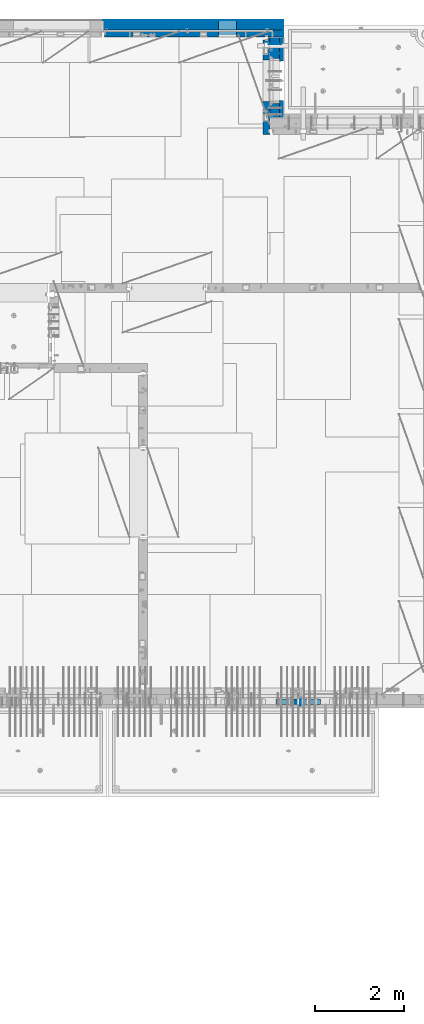
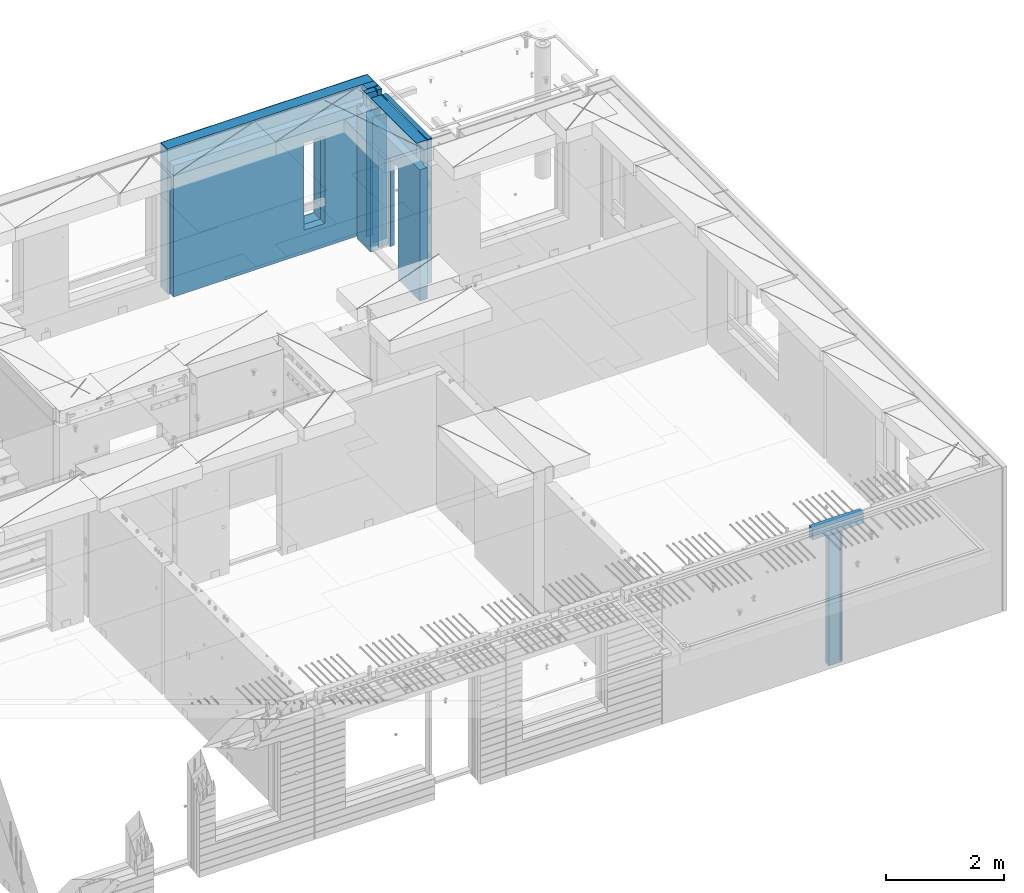
# One storey, part 240 of 349: 13 walls, 5 elements without a shape of their own.
"""IFC2X3 building model written with IfcOpenShell, lengths in millimetres."""

from ifc_helpers import new_model, si_unit, frame, origin_with_axes, place, context, subcontext, project, spatial, faceted_brep, material, type_object, element, aggregate, save


model = new_model("IFC2X3")

# Units and contexts
model_context = context("Model", 3, precision=1e-05, world=origin_with_axes())
body_context = subcontext(model_context, "Body", "Model", "MODEL_VIEW")
ifc_project = project(units=[si_unit("LENGTHUNIT", "METRE", prefix="MILLI"), si_unit("AREAUNIT", "SQUARE_METRE"), si_unit("VOLUMEUNIT", "CUBIC_METRE"), si_unit("MASSUNIT", "GRAM", prefix="KILO"), si_unit("TIMEUNIT", "SECOND"), si_unit("PLANEANGLEUNIT", "RADIAN"), si_unit("SOLIDANGLEUNIT", "STERADIAN"), si_unit("THERMODYNAMICTEMPERATUREUNIT", "DEGREE_CELSIUS"), si_unit("LUMINOUSINTENSITYUNIT", "LUMEN")], contexts=[model_context])

# Site, building, storey
site_placement = place(None, origin_with_axes())
site = spatial("IfcSite", under=ifc_project, at=site_placement, CompositionType="ELEMENT")
building_placement = place(site_placement, origin_with_axes())
building = spatial("IfcBuilding", under=site, at=building_placement, CompositionType="ELEMENT")
storey_placement = place(building_placement, origin_with_axes())
storey = spatial("IfcBuildingStorey", under=building, at=storey_placement, Name="4", CompositionType="ELEMENT", Elevation=0.0)

# Assembly, wall
assembly_1_placement = place(storey_placement, origin_with_axes())
assembly_1 = element("IfcElementAssembly", 1, at=assembly_1_placement, inside=storey, AssemblyPlace="NOTDEFINED", PredefinedType="REINFORCEMENT_UNIT")
ifc_material_1 = material(Name="Undefined")
wall_type_1 = type_object("IfcWallType", PredefinedType="NOTDEFINED")
wall_1_placement = place(assembly_1_placement, frame((32144.9998946285, 7780.0, 92115.0), z_axis=(0.0, 0.0, 1.0), x_axis=(0.0, -1.0, 0.0)))
wall_1 = element("IfcWall", 2, at=wall_1_placement, type_object=wall_type_1, material=ifc_material_1, Name="(PD)", context=body_context, shape_type="Brep", body=[
    faceted_brep([(0.0, 5.0, -1300.0), (0.0, 5.0, 1300.0), (180.0, 5.0, 1300.0), (180.0, 5.0, -1300.0), (0.0, -5.0, 1300.0), (180.0, -5.0, 1300.0), (0.0, -5.0, -1300.0), (180.0, -5.0, -1300.0)], [[[0, 1, 2, 3]], [[1, 4, 5, 2]], [[4, 6, 7, 5]], [[6, 0, 3, 7]], [[5, 7, 3, 2]], [[6, 4, 1, 0]]]),
])

# Assembly, walls
assembly_2_placement = place(storey_placement, origin_with_axes())
assembly_2 = element("IfcElementAssembly", 3, at=assembly_2_placement, inside=storey, AssemblyPlace="NOTDEFINED", PredefinedType="REINFORCEMENT_UNIT")
wall_2_placement = place(assembly_2_placement, frame((31429.9951872276, 22245.0, 92115.0), z_axis=(0.0, 0.0, 1.0), x_axis=(1.0, 0.0, 0.0)))
wall_2 = element("IfcWall", 4, at=wall_2_placement, type_object=wall_type_1, material=ifc_material_1, Name="(PD)", context=body_context, shape_type="Brep", body=[
    faceted_brep([(0.0, 5.0, -1300.0), (0.0, 5.0, 1300.0), (280.0, 5.0, 1300.0), (280.0, 5.0, -1300.0), (0.0, -5.0, 1300.0), (280.0, -5.0, 1300.0), (0.0, -5.0, -1300.0), (280.0, -5.0, -1300.0)], [[[0, 1, 2, 3]], [[1, 4, 5, 2]], [[4, 6, 7, 5]], [[6, 0, 3, 7]], [[5, 7, 3, 2]], [[6, 4, 1, 0]]]),
])
wall_3_placement = place(assembly_2_placement, frame((31429.9951872276, 22454.9997558594, 92115.0), z_axis=(0.0, 0.0, 1.0), x_axis=(1.0, 0.0, 0.0)))
wall_3 = element("IfcWall", 5, at=wall_3_placement, type_object=wall_type_1, material=ifc_material_1, Name="(PD)", context=body_context, shape_type="Brep", body=[
    faceted_brep([(0.0, 5.0, -1300.0), (0.0, 5.0, 1300.0), (280.0, 5.0, 1300.0), (280.0, 5.0, -1300.0), (0.0, -5.0, 1300.0), (280.0, -5.0, 1300.0), (0.0, -5.0, -1300.0), (280.0, -5.0, -1300.0)], [[[0, 1, 2, 3]], [[1, 4, 5, 2]], [[4, 6, 7, 5]], [[6, 0, 3, 7]], [[5, 7, 3, 2]], [[6, 4, 1, 0]]]),
])

# Assemblies, wall
assembly_3_placement = place(storey_placement, origin_with_axes())
assembly_3 = element("IfcElementAssembly", 6, at=assembly_3_placement, inside=storey, AssemblyPlace="NOTDEFINED", PredefinedType="REINFORCEMENT_UNIT")
assembly_4_placement = place(assembly_3_placement, origin_with_axes())
assembly_4 = element("IfcElementAssembly", 7, at=assembly_4_placement, Name="Steel Assembly", AssemblyPlace="NOTDEFINED", PredefinedType="NOTDEFINED")
aggregate(assembly_3, [assembly_4])
ifc_material_2 = material()
wall_type_2 = type_object("IfcWallType", PredefinedType="NOTDEFINED")
wall_4_placement = place(assembly_4_placement, frame((31599.9998568133, 7690.00021946163, 93590.0), z_axis=(0.0, 0.0, 1.0), x_axis=(1.0, 0.0, 0.0)))
wall_4 = element("IfcWall", 8, at=wall_4_placement, type_object=wall_type_2, material=ifc_material_2, context=body_context, shape_type="Brep", body=[
    faceted_brep([(0.0, 60.0, -120.0), (0.0, 60.0, 120.0), (1000.0, 60.0, 120.0), (1000.0, 60.0, -120.0), (0.0, -60.0, 120.0), (1000.0, -60.0, 120.0), (0.0, -60.0, -120.0), (1000.0, -60.0, -120.0)], [[[0, 1, 2, 3]], [[1, 4, 5, 2]], [[4, 6, 7, 5]], [[6, 0, 3, 7]], [[5, 7, 3, 2]], [[6, 4, 1, 0]]]),
])
aggregate(assembly_4, [wall_4])

# Wall
ifc_material_3 = material(Name="COS5gt")
wall_type_3 = type_object("IfcWallType", PredefinedType="NOTDEFINED")
wall_5_placement = place(assembly_2_placement, frame((31569.9951872276, 22605.0, 92247.5), z_axis=(0.0, 0.0, 1.0), x_axis=(0.0, -1.0, 0.0)))
wall_5 = element("IfcWall", 9, at=wall_5_placement, type_object=wall_type_3, material=ifc_material_3, context=body_context, shape_type="Brep", body=[
    faceted_brep([(0.0, 90.0, -1492.5), (0.0, 90.0, -1442.5), (465.000109818619, 90.0, -1442.5), (465.000109818619, 90.0, -1492.5), (0.0, -110.0, -1492.5), (465.000109818619, -110.0, -1492.5), (1800.0, -110.0, 1492.5), (1800.0, 90.0, 1492.5), (255.0, 90.0, 1492.5), (255.0, -110.0, 1492.5), (1800.0, 90.0, -1442.5), (1800.0, 90.0, -1492.5), (1475.00010981862, 90.0, -1492.5), (1475.00010981862, 90.0, -1442.5), (1800.0, 110.0, -1442.5), (1475.00010981862, 110.0, -1442.5), (1800.0, 110.0, 1442.5), (1800.0, 90.0, 1442.5), (1800.0, -110.0, -1492.5), (1475.00010981862, -110.0, -1492.5), (1475.00010981862, -110.000000000004, 857.5), (1475.00010981862, 110.0, 857.5), (465.000109818619, -110.000000000004, 857.5), (465.000109818619, 110.0, 857.5), (255.0, -110.0, 1222.5), (105.0, -110.0, 1222.5), (105.0, -110.0, 1492.5), (0.0, -110.0, 1492.5), (0.0, 90.0, 1492.5), (105.0, 90.0, 1492.5), (0.0, 110.0, 1442.5), (0.0, 90.0, 1442.5), (105.0, 90.0, 1442.5), (105.0, 110.0, 1442.5), (0.0, 110.0, -1442.5), (465.000109818619, 110.0, -1442.5), (105.0, 110.0, 1222.5), (255.0, 110.0, 1222.5), (255.0, 110.0, 1442.5), (255.0, 90.0, 1442.5)], [[[0, 1, 2, 3]], [[4, 0, 3, 5]], [[6, 7, 8, 9]], [[10, 11, 12, 13]], [[14, 10, 13, 15]], [[16, 17, 7, 6, 18, 11, 10, 14]], [[11, 18, 19, 12]], [[15, 13, 12, 19, 20, 21]], [[21, 20, 22, 23]], [[19, 18, 6, 9, 24, 25, 26, 27, 4, 5, 22, 20]], [[28, 27, 26, 29]], [[30, 31, 32, 33]], [[0, 4, 27, 28, 31, 30, 34, 1]], [[1, 34, 35, 2]], [[23, 22, 5, 3, 2, 35]], [[34, 30, 33, 36, 37, 38, 16, 14, 15, 21, 23, 35]], [[17, 16, 38, 39]], [[7, 17, 39, 8]], [[38, 37, 24, 9, 8, 39]], [[36, 25, 24, 37]], [[33, 32, 29, 26, 25, 36]], [[31, 28, 29, 32]]]),
])

# Assembly, walls
assembly_5_placement = place(storey_placement, origin_with_axes())
assembly_5 = element("IfcElementAssembly", 10, at=assembly_5_placement, inside=storey, AssemblyPlace="NOTDEFINED", PredefinedType="REINFORCEMENT_UNIT")
ifc_material_4 = material()
wall_6_placement = place(assembly_5_placement, frame((31645.0, 22620.0, 92247.5), z_axis=(0.0, 0.0, 1.0), x_axis=(0.0, 1.0, 0.0)))
wall_6 = element("IfcWall", 11, at=wall_6_placement, type_object=wall_type_3, material=ifc_material_4, context=body_context, shape_type="Brep", body=[
    faceted_brep([(0.0, 110.0, -1492.5), (0.0, 110.0, 1492.5), (150.0, 110.0, 1492.5), (150.0, 110.0, -1492.5), (0.0, -110.0, 1492.5), (150.0, -110.0, 1492.5), (0.0, -110.0, -1492.5), (150.0, -110.0, -1492.5)], [[[0, 1, 2, 3]], [[1, 4, 5, 2]], [[4, 6, 7, 5]], [[6, 0, 3, 7]], [[5, 7, 3, 2]], [[6, 4, 1, 0]]]),
])
wall_7_placement = place(assembly_5_placement, frame((27720.0, 22880.0, 92247.5), z_axis=(0.0, 0.0, 1.0), x_axis=(1.0, 0.0, 0.0)))
wall_7 = element("IfcWall", 12, at=wall_7_placement, type_object=wall_type_3, material=ifc_material_4, context=body_context, shape_type="Brep", body=[
    faceted_brep([(0.0, -110.0, -1492.5), (0.0, 110.0, -1492.5), (4035.0, 110.0, -1492.5), (4035.0, -110.0, -1492.5), (0.0, -110.0, 1492.5), (0.0, 110.0, 1492.5), (4035.0, -110.0, 1492.5), (4035.0, 110.0, 1492.5), (2584.99948280293, 110.0, -1002.5), (2994.99948280293, 110.0, -1002.5), (2994.99948280293, 110.0, 807.5), (2584.99948280293, 110.0, 807.5), (2584.99948280293, -110.0, -1002.5), (2584.99948280293, -110.0, 807.5), (2994.99948280293, -110.0, 807.5), (2994.99948280293, -110.0, -1002.5)], [[[0, 1, 2, 3]], [[0, 4, 5, 1]], [[5, 4, 6, 7]], [[1, 5, 7, 2], [8, 9, 10, 11]], [[6, 3, 2, 7]], [[4, 0, 3, 6], [12, 13, 14, 15]], [[10, 14, 13, 11]], [[9, 15, 14, 10]], [[8, 12, 15, 9]], [[11, 13, 12, 8]]]),
])

# Wall
ifc_material_5 = material(Name="CONCRETE/C30/37")
wall_type_4 = type_object("IfcWallType", PredefinedType="NOTDEFINED")
wall_8_placement = place(assembly_2_placement, frame((31722.4951872276, 22605.0, 92247.5), z_axis=(0.0, 0.0, 1.0), x_axis=(0.0, -1.0, 0.0)))
wall_8 = element("IfcWall", 13, at=wall_8_placement, type_object=wall_type_4, material=ifc_material_5, context=body_context, shape_type="Brep", body=[
    faceted_brep([(0.0, 32.4999992507037, 744.999999999258), (0.0, 32.4999991127006, 755.00000040044), (526.17471776616, 32.4999991126897, 755.000000400425), (526.174717749924, 32.4999992507001, 744.999999999229), (0.0, 42.5, 742.999999944761), (524.998050995091, 42.4999995462422, 742.999999944761), (0.0, 42.5, 606.999999889245), (524.998050995091, 42.4999994639038, 606.999999889245), (3.63797880709171e-12, 32.4999991127006, 605.00000040044), (526.17471776616, 32.4999991126897, 605.000000400425), (3.63797880709171e-12, 32.4999992507037, 594.999999999258), (526.174717749924, 32.4999992507001, 594.999999999229), (0.0, 42.5, 592.999999944761), (524.998050995091, 42.4999995343132, 592.999999944761), (0.0, 42.5, 456.999999889245), (524.998050995091, 42.4999994639038, 456.999999889245), (0.0, 32.4999991127006, 455.00000040044), (526.17471776616, 32.4999991126897, 455.000000400425), (0.0, 32.4999992507037, 444.999999999258), (526.174717749924, 32.4999992507001, 444.999999999229), (0.0, 42.5, 442.999999944761), (524.998050995091, 42.4999995254038, 442.999999944761), (0.0, 42.5, 306.999999889245), (524.998050995091, 42.4999994639038, 306.999999889245), (-3.63797880709171e-12, 32.4999991127006, 305.00000040044), (526.17471776616, 32.4999991126897, 305.000000400425), (-3.63797880709171e-12, 32.4999992507037, 294.999999999258), (526.174717749924, 32.4999992507001, 294.999999999229), (0.0, 42.5, 292.999999944761), (524.998050995091, 42.499999518499, 292.999999944761), (0.0, 42.5, 156.999999889245), (524.998050995091, 42.4999994639038, 156.999999889245), (-3.63797880709171e-12, 32.4999991127006, 155.00000040044), (526.17471776616, 32.4999991126897, 155.000000400425), (-3.63797880709171e-12, 32.4999992507037, 144.999999999258), (526.174717749924, 32.4999992507001, 144.999999999229), (0.0, 42.5, 142.999999944761), (524.998050995091, 42.4999995129838, 142.999999944761), (0.0, 42.5, 6.99999988924537), (524.998050995091, 42.4999994639038, 6.99999988924537), (0.0, 32.4999991127006, 5.0000004004396), (526.17471776616, 32.4999991126897, 5.00000040042505), (0.0, 32.4999992507037, -5.00000000074215), (526.174717749924, 32.4999992507001, -5.00000000077125), (0.0, 42.5, -7.00000005523907), (524.998050995091, 42.49999950848, -7.00000005523907), (0.0, 42.5, -143.000000110755), (524.998050995091, 42.4999994639038, -143.000000110755), (3.63797880709171e-12, 32.4999991127006, -144.99999959956), (526.17471776616, 32.4999991126897, -144.999999599575), (3.63797880709171e-12, 32.4999992507037, -155.000000000742), (526.174717749924, 32.4999992507001, -155.000000000771), (0.0, 42.5, -157.000000055239), (524.998050995091, 42.4999995047365, -157.000000055239), (0.0, 42.5, -293.000000110755), (524.998050995091, 42.4999994639038, -293.000000110755), (0.0, 32.4999991127006, -294.99999959956), (526.17471776616, 32.4999991126897, -294.999999599575), (0.0, 32.4999992507037, -305.000000000742), (526.174717749924, 32.4999992507001, -305.000000000771), (0.0, 42.5, -307.000000055239), (524.998050995091, 42.4999995015714, -307.000000055239), (0.0, 42.5, -443.000000110755), (524.998050995091, 42.4999994639038, -443.000000110755), (0.0, 32.4999991127006, -444.99999959956), (526.17471776616, 32.4999991126897, -444.999999599575), (0.0, 32.4999992507037, -455.000000000742), (526.174717749924, 32.4999992507001, -455.000000000771), (0.0, 42.5, -457.000000055239), (524.998050995091, 42.4999994988648, -457.000000055239), (0.0, 42.5, -593.000000110755), (524.998050995091, 42.4999994639038, -593.000000110755), (3.63797880709171e-12, 32.4999991127006, -594.99999959956), (526.17471776616, 32.4999991126897, -594.999999599575), (3.63797880709171e-12, 32.4999992507037, -605.000000000742), (526.174717749924, 32.4999992507001, -605.000000000771), (0.0, 42.5, -607.000000055239), (524.998050995091, 42.4999994965183, -607.000000055239), (0.0, 42.5, -743.000000110755), (524.998050995091, 42.4999994639038, -743.000000110755), (0.0, 32.4999991127006, -744.99999959956), (526.17471776616, 32.4999991126897, -744.999999599575), (0.0, 32.4999992507037, -755.000000000742), (526.174717749924, 32.4999992507001, -755.000000000771), (0.0, 42.5, -757.000000055239), (524.998050995091, 42.4999994944665, -757.000000055239), (0.0, 42.5, -893.000000110755), (524.998050995091, 42.4999994639038, -893.000000110755), (0.0, 32.4999991127006, -894.99999959956), (526.17471776616, 32.4999991126897, -894.999999599575), (0.0, 32.4999992507037, -905.000000000742), (526.174717749924, 32.4999992507001, -905.000000000771), (0.0, 42.5, -907.000000055239), (524.998050995091, 42.4999994926584, -907.000000055239), (0.0, 42.5, -1043.00000011075), (524.998050995091, 42.4999994639038, -1043.00000011075), (0.0, 32.4999991127006, -1044.99999959956), (526.17471776616, 32.4999991126897, -1044.99999959957), (0.0, 32.4999992507037, -1055.00000000074), (526.174717749924, 32.4999992507001, -1055.00000000077), (0.0, 42.5, -1057.00000005524), (524.998050995091, 42.499999491054, -1057.00000005524), (0.0, 42.5, -1193.00000011075), (524.998050995091, 42.4999994639038, -1193.00000011075), (0.0, 32.4999991127006, -1194.99999959956), (526.17471776616, 32.4999991126897, -1194.99999959957), (0.0, 32.4999992507037, -1205.00000000074), (526.174717749924, 32.4999992507001, -1205.00000000077), (0.0, 42.5, -1207.00000005524), (524.998050995091, 42.499999489617, -1207.00000005524), (0.0, 42.5, -1343.00000011075), (524.998050995091, 42.4999994639038, -1343.00000011075), (0.0, 32.4999991127006, -1344.99999959956), (526.17471776616, 32.4999991126897, -1344.99999959957), (0.0, 32.4999992507037, -1355.00000000074), (526.174717749924, 32.4999992507001, -1355.00000000077), (0.0, 42.5, -1357.00000005524), (524.998050995091, 42.5, -1357.00000005524), (0.0, 42.5, -1492.5), (524.998050995091, 42.5, -1492.5), (0.0, 42.5, 1356.99999988925), (0.0, 42.5, 1492.5), (105.0, 42.5, 1492.5), (105.0, 42.499999287309, 1356.99999988925), (0.0, -42.5, 1492.5), (105.0, -42.5, 1492.5), (1800.0, 32.4999991126897, 755.000000400425), (1800.0, 32.4999992507001, 744.999999999229), (1413.82138424026, 32.4999992507001, 744.999999999229), (1413.82138422402, 32.4999991126897, 755.000000400425), (1800.0, 42.5, 742.999999944761), (1414.99805099509, 42.4999998629828, 742.999999944761), (1800.0, 42.5, 606.999999889245), (1414.99805099509, 42.4999998381209, 606.999999889245), (1800.0, 32.4999991126897, 605.000000400425), (1413.82138422402, 32.4999991126897, 605.000000400425), (1800.0, 32.4999992507001, 594.999999999229), (1413.82138424026, 32.4999992507001, 594.999999999229), (1800.0, 42.5, 592.999999944761), (1414.99805099509, 42.4999998593812, 592.999999944761), (1800.0, 42.5, 456.999999889245), (1414.99805099509, 42.4999998381209, 456.999999889245), (1800.0, 32.4999991126897, 455.000000400425), (1413.82138422402, 32.4999991126897, 455.000000400425), (1800.0, 32.4999992507001, 444.999999999229), (1413.82138424026, 32.4999992507001, 444.999999999229), (1800.0, 42.5, 442.999999944761), (1414.99805099509, 42.4999998566891, 442.999999944761), (1800.0, 42.5, 306.999999889245), (1414.99805099509, 42.4999998381209, 306.999999889245), (1800.0, 32.4999991126897, 305.000000400425), (1413.82138422402, 32.4999991126897, 305.000000400425), (1800.0, 32.4999992507001, 294.999999999229), (1413.82138424026, 32.4999992507001, 294.999999999229), (1800.0, 42.5, 292.999999944761), (1414.99805099509, 42.4999998546045, 292.999999944761), (1800.0, 42.5, 156.999999889245), (1414.99805099509, 42.4999998381209, 156.999999889245), (1800.0, 32.4999991126897, 155.000000400425), (1413.82138422402, 32.4999991126897, 155.000000400425), (1800.0, 32.4999992507001, 144.999999999229), (1413.82138424026, 32.4999992507001, 144.999999999229), (1800.0, 42.5, 142.999999944761), (1414.99805099509, 42.4999998529383, 142.999999944761), (1800.0, 42.5, 6.99999988924537), (1414.99805099509, 42.4999998381209, 6.99999988924537), (1800.0, 32.4999991126897, 5.00000040042505), (1413.82138422402, 32.4999991126897, 5.00000040042505), (1800.0, 32.4999992507001, -5.00000000077125), (1413.82138424026, 32.4999992507001, -5.00000000077125), (1800.0, 42.5, -7.00000005523907), (1414.99805099509, 42.4999998515814, -7.00000005523907), (1800.0, 42.5, -143.000000110755), (1414.99805099509, 42.4999998381209, -143.000000110755), (1800.0, 32.4999991126897, -144.999999599575), (1413.82138422402, 32.4999991126897, -144.999999599575), (1800.0, 32.4999992507001, -155.000000000771), (1413.82138424026, 32.4999992507001, -155.000000000771), (1800.0, 42.5, -157.000000055239), (1414.99805099509, 42.49999985045, -157.000000055239), (1800.0, 42.5, -293.000000110755), (1414.99805099509, 42.4999998381209, -293.000000110755), (1800.0, 32.4999991126897, -294.999999599575), (1413.82138422402, 32.4999991126897, -294.999999599575), (1800.0, 32.4999992507001, -305.000000000771), (1413.82138424026, 32.4999992507001, -305.000000000771), (1800.0, 42.5, -307.000000055239), (1414.99805099509, 42.4999998494932, -307.000000055239), (1800.0, 42.5, -443.000000110755), (1414.99805099509, 42.4999998381209, -443.000000110755), (1800.0, 32.4999991126897, -444.999999599575), (1413.82138422402, 32.4999991126897, -444.999999599575), (1800.0, 32.4999992507001, -455.000000000771), (1413.82138424026, 32.4999992507001, -455.000000000771), (1800.0, 42.5, -457.000000055239), (1414.99805099509, 42.4999998486746, -457.000000055239), (1800.0, 42.5, -593.000000110755), (1414.99805099509, 42.4999998381209, -593.000000110755), (1800.0, 32.4999991126897, -594.999999599575), (1413.82138422402, 32.4999991126897, -594.999999599575), (1800.0, 32.4999992507001, -605.000000000771), (1413.82138424026, 32.4999992507001, -605.000000000771), (1800.0, 42.5, -607.000000055239), (1414.99805099509, 42.4999998479689, -607.000000055239), (1800.0, 42.5, -743.000000110755), (1414.99805099509, 42.4999998381209, -743.000000110755), (1800.0, 32.4999991126897, -744.999999599575), (1413.82138422402, 32.4999991126897, -744.999999599575), (1800.0, 32.4999992507001, -755.000000000771), (1413.82138424026, 32.4999992507001, -755.000000000771), (1800.0, 42.5, -757.000000055239), (1414.99805099509, 42.4999998473468, -757.000000055239), (1800.0, 42.5, -893.000000110755), (1414.99805099509, 42.4999998381209, -893.000000110755), (1800.0, 32.4999991126897, -894.999999599575), (1413.82138422402, 32.4999991126897, -894.999999599575), (1800.0, 32.4999992507001, -905.000000000771), (1413.82138424026, 32.4999992507001, -905.000000000771), (1800.0, 42.5, -907.000000055239), (1414.99805099509, 42.4999998468011, -907.000000055239), (1800.0, 42.5, -1043.00000011075), (1414.99805099509, 42.4999998381209, -1043.00000011075), (1800.0, 32.4999991126897, -1044.99999959957), (1413.82138422402, 32.4999991126897, -1044.99999959957), (1800.0, 32.4999992507001, -1055.00000000077), (1413.82138424026, 32.4999992507001, -1055.00000000077), (1800.0, 42.5, -1057.00000005524), (1414.99805099509, 42.4999998463172, -1057.00000005524), (1800.0, 42.5, -1193.00000011075), (1414.99805099509, 42.4999998381209, -1193.00000011075), (1800.0, 32.4999991126897, -1194.99999959957), (1413.82138422402, 32.4999991126897, -1194.99999959957), (1800.0, 32.4999992507001, -1205.00000000077), (1413.82138424026, 32.4999992507001, -1205.00000000077), (1800.0, 42.5, -1207.00000005524), (1414.99805099509, 42.4999998458843, -1207.00000005524), (1800.0, 42.5, -1343.00000011075), (1414.99805099509, 42.4999998381209, -1343.00000011075), (1800.0, 32.4999991126897, -1344.99999959957), (1413.82138422402, 32.4999991126897, -1344.99999959957), (1800.0, 32.4999992507001, -1355.00000000077), (1413.82138424026, 32.4999992507001, -1355.00000000077), (1800.0, 42.5, -1357.00000005524), (1414.99805099509, 42.5, -1357.00000005524), (1800.0, 42.5, -1492.5), (1414.99805099509, 42.5, -1492.5), (1800.0, -42.5, -1492.5), (1404.99638432842, -42.5, -1492.5), (1414.99805099509, 42.4999998381209, 756.999999889245), (1404.99638432842, -42.5000000000036, 782.5), (1404.99638432842, -42.5000000000036, 787.502857142856), (1414.99805099509, 42.5, 782.5), (1800.0, 42.5, 756.999999889245), (0.0, 42.5, 892.999999944761), (0.0, 32.4999992507037, 894.999999999258), (1800.0, 32.4999992507001, 894.999999999229), (1800.0, 42.5, 892.999999944761), (0.0, 32.4999991127006, 905.00000040044), (1800.0, 32.4999991126897, 905.000000400425), (0.0, 42.5, 906.999999889245), (1800.0, 42.5, 906.999999889245), (0.0, 42.5, 1042.99999994476), (1800.0, 42.5, 1042.99999994476), (0.0, 32.4999992507037, 1044.99999999926), (1800.0, 32.4999992507001, 1044.99999999923), (0.0, 32.4999991127006, 1055.00000040044), (1800.0, 32.4999991126897, 1055.00000040043), (0.0, 42.5, 1056.99999988925), (1800.0, 42.5, 1056.99999988925), (0.0, 42.5, 1192.99999994476), (1800.0, 42.5, 1192.99999994476), (1800.0, -42.5, 1492.5), (1800.0, 42.5, 1492.5), (255.0, 42.5, 1492.5), (255.0, -42.5, 1492.5), (1800.0, 42.5, 1356.99999988925), (255.0, 42.499999350377, 1356.99999988925), (1800.0, 32.4999991126897, 1355.00000040043), (1800.0, 32.4999992507001, 1344.99999999923), (255.0, 32.4999992507001, 1344.99999999923), (255.0, 32.4999991126897, 1355.00000040043), (1800.0, 42.5, 1342.99999994476), (255.0, 42.4999996598308, 1342.99999994476), (105.0, 42.4999993874699, 1222.5), (105.0, -42.5, 1222.5), (255.0, -42.5, 1222.5), (255.0, 42.4999994355167, 1222.5), (1800.0, 32.4999992507001, 1194.99999999923), (1800.0, 32.4999991126897, 1205.00000040043), (1800.0, 42.5, 1206.99999988925), (0.0, 32.4999992507037, 1194.99999999926), (0.0, 32.4999991127006, 1205.00000040044), (0.0, 42.5, 1206.99999988925), (0.0, 42.5, 1342.99999994476), (105.0, 42.4999996268052, 1342.99999994476), (-3.63797880709171e-12, 32.4999992507037, 1344.99999999926), (105.0, 32.4999992507001, 1344.99999999923), (-3.63797880709171e-12, 32.4999991127006, 1355.00000040044), (105.0, 32.4999991126897, 1355.00000040043), (0.0, 42.5, 756.999999889245), (0.0, -42.5, -1492.5), (534.999717661754, -42.5, -1492.5), (534.999717661758, -42.5000000000036, 782.5), (534.999717661758, -42.5000000000036, 787.502857142856), (535.000109818619, 42.5, 782.5), (1405.00010981862, 42.5, 782.5), (524.998050995091, 42.5, 782.5), (524.998050995091, 42.4999994639038, 756.999999889245)], [[[0, 1, 2, 3]], [[4, 0, 3, 5]], [[6, 4, 5, 7]], [[8, 6, 7, 9]], [[10, 8, 9, 11]], [[12, 10, 11, 13]], [[14, 12, 13, 15]], [[16, 14, 15, 17]], [[18, 16, 17, 19]], [[20, 18, 19, 21]], [[22, 20, 21, 23]], [[24, 22, 23, 25]], [[26, 24, 25, 27]], [[28, 26, 27, 29]], [[30, 28, 29, 31]], [[32, 30, 31, 33]], [[34, 32, 33, 35]], [[36, 34, 35, 37]], [[38, 36, 37, 39]], [[40, 38, 39, 41]], [[42, 40, 41, 43]], [[44, 42, 43, 45]], [[46, 44, 45, 47]], [[48, 46, 47, 49]], [[50, 48, 49, 51]], [[52, 50, 51, 53]], [[54, 52, 53, 55]], [[56, 54, 55, 57]], [[58, 56, 57, 59]], [[60, 58, 59, 61]], [[62, 60, 61, 63]], [[64, 62, 63, 65]], [[66, 64, 65, 67]], [[68, 66, 67, 69]], [[70, 68, 69, 71]], [[72, 70, 71, 73]], [[74, 72, 73, 75]], [[76, 74, 75, 77]], [[78, 76, 77, 79]], [[80, 78, 79, 81]], [[82, 80, 81, 83]], [[84, 82, 83, 85]], [[86, 84, 85, 87]], [[88, 86, 87, 89]], [[90, 88, 89, 91]], [[92, 90, 91, 93]], [[94, 92, 93, 95]], [[96, 94, 95, 97]], [[98, 96, 97, 99]], [[100, 98, 99, 101]], [[102, 100, 101, 103]], [[104, 102, 103, 105]], [[106, 104, 105, 107]], [[108, 106, 107, 109]], [[110, 108, 109, 111]], [[112, 110, 111, 113]], [[114, 112, 113, 115]], [[116, 114, 115, 117]], [[118, 116, 117, 119]], [[120, 121, 122, 123]], [[121, 124, 125, 122]], [[126, 127, 128, 129]], [[127, 130, 131, 128]], [[130, 132, 133, 131]], [[132, 134, 135, 133]], [[134, 136, 137, 135]], [[136, 138, 139, 137]], [[138, 140, 141, 139]], [[140, 142, 143, 141]], [[142, 144, 145, 143]], [[144, 146, 147, 145]], [[146, 148, 149, 147]], [[148, 150, 151, 149]], [[150, 152, 153, 151]], [[152, 154, 155, 153]], [[154, 156, 157, 155]], [[156, 158, 159, 157]], [[158, 160, 161, 159]], [[160, 162, 163, 161]], [[162, 164, 165, 163]], [[164, 166, 167, 165]], [[166, 168, 169, 167]], [[168, 170, 171, 169]], [[170, 172, 173, 171]], [[172, 174, 175, 173]], [[174, 176, 177, 175]], [[176, 178, 179, 177]], [[178, 180, 181, 179]], [[180, 182, 183, 181]], [[182, 184, 185, 183]], [[184, 186, 187, 185]], [[186, 188, 189, 187]], [[188, 190, 191, 189]], [[190, 192, 193, 191]], [[192, 194, 195, 193]], [[194, 196, 197, 195]], [[196, 198, 199, 197]], [[198, 200, 201, 199]], [[200, 202, 203, 201]], [[202, 204, 205, 203]], [[204, 206, 207, 205]], [[206, 208, 209, 207]], [[208, 210, 211, 209]], [[210, 212, 213, 211]], [[212, 214, 215, 213]], [[214, 216, 217, 215]], [[216, 218, 219, 217]], [[218, 220, 221, 219]], [[220, 222, 223, 221]], [[222, 224, 225, 223]], [[224, 226, 227, 225]], [[226, 228, 229, 227]], [[228, 230, 231, 229]], [[230, 232, 233, 231]], [[232, 234, 235, 233]], [[234, 236, 237, 235]], [[236, 238, 239, 237]], [[238, 240, 241, 239]], [[240, 242, 243, 241]], [[242, 244, 245, 243]], [[244, 246, 247, 245]], [[248, 129, 128, 131, 133, 135, 137, 139, 141, 143, 145, 147, 149, 151, 153, 155, 157, 159, 161, 163, 165, 167, 169, 171, 173, 175, 177, 179, 181, 183, 185, 187, 189, 191, 193, 195, 197, 199, 201, 203, 205, 207, 209, 211, 213, 215, 217, 219, 221, 223, 225, 227, 229, 231, 233, 235, 237, 239, 241, 243, 245, 247, 249, 250, 251]], [[252, 126, 129, 248]], [[253, 254, 255, 256]], [[257, 258, 255, 254]], [[259, 260, 258, 257]], [[260, 259, 261, 262]], [[261, 263, 264, 262]], [[265, 266, 264, 263]], [[267, 268, 266, 265]], [[268, 267, 269, 270]], [[271, 272, 273, 274]], [[272, 275, 276, 273]], [[277, 278, 279, 280]], [[278, 281, 282, 279]], [[283, 284, 285, 286]], [[273, 276, 280, 279, 282, 286, 285, 274]], [[275, 277, 280, 276]], [[272, 271, 246, 244, 242, 240, 238, 236, 234, 232, 230, 228, 226, 224, 222, 220, 218, 216, 214, 212, 210, 208, 206, 204, 202, 200, 198, 196, 194, 192, 190, 188, 186, 184, 182, 180, 178, 176, 174, 172, 170, 168, 166, 164, 162, 160, 158, 156, 154, 152, 150, 148, 146, 144, 142, 140, 138, 136, 134, 132, 130, 127, 126, 252, 256, 255, 258, 260, 262, 264, 266, 268, 270, 287, 288, 289, 281, 278, 277, 275]], [[269, 290, 287, 270]], [[291, 288, 287, 290]], [[292, 289, 288, 291]], [[286, 282, 281, 289, 292, 293, 294, 283]], [[293, 295, 296, 294]], [[295, 297, 298, 296]], [[122, 125, 284, 283, 294, 296, 298, 123]], [[297, 120, 123, 298]], [[295, 293, 292, 291, 290, 269, 267, 265, 263, 261, 259, 257, 254, 253, 299, 1, 0, 4, 6, 8, 10, 12, 14, 16, 18, 20, 22, 24, 26, 28, 30, 32, 34, 36, 38, 40, 42, 44, 46, 48, 50, 52, 54, 56, 58, 60, 62, 64, 66, 68, 70, 72, 74, 76, 78, 80, 82, 84, 86, 88, 90, 92, 94, 96, 98, 100, 102, 104, 106, 108, 110, 112, 114, 116, 118, 300, 124, 121, 120, 297]], [[249, 247, 246, 271, 274, 285, 284, 125, 124, 300, 301, 302, 303, 250]], [[304, 305, 251, 250, 303, 306]], [[299, 253, 256, 252, 248, 251, 305, 304, 306, 307]], [[1, 299, 307, 2]], [[306, 303, 302, 301, 119, 117, 115, 113, 111, 109, 107, 105, 103, 101, 99, 97, 95, 93, 91, 89, 87, 85, 83, 81, 79, 77, 75, 73, 71, 69, 67, 65, 63, 61, 59, 57, 55, 53, 51, 49, 47, 45, 43, 41, 39, 37, 35, 33, 31, 29, 27, 25, 23, 21, 19, 17, 15, 13, 11, 9, 7, 5, 3, 2, 307]], [[300, 118, 119, 301]]]),
])

ifc_material_6 = material(Name="CONCRETE/C25/30")
wall_type_5 = type_object("IfcWallType", PredefinedType="NOTDEFINED")
wall_9_placement = place(assembly_2_placement, frame((31384.9951872276, 22620.0, 92112.5), z_axis=(0.0, 0.0, 1.0), x_axis=(0.0, -1.0, 0.0)))
wall_9 = element("IfcWall", 14, at=wall_9_placement, type_object=wall_type_5, material=ifc_material_6, context=body_context, shape_type="Brep", body=[
    faceted_brep([(2190.00481277244, -75.0, 1357.5), (2190.00481277244, -75.0, -1357.5), (2190.00481277244, 75.0, -1357.5), (2190.00481277244, 75.0, 1357.5), (2168.00481277244, 75.0, -1357.5), (2168.00481277244, 75.0, 1357.5), (2155.00481277244, 55.0, -1357.5), (2155.00481277244, 55.0, 1357.5), (2075.00481277244, 55.0, -1357.5), (2075.00481277244, 55.0, 1357.5), (2062.00481277244, 75.0, 1357.5), (2062.00481277244, 75.0, -1357.5), (15.0, 75.0, 1357.5), (15.0, 53.6666666666642, 1357.5), (65.0, 32.0, 1357.5), (65.0, -75.0, 1357.5), (15.0, 75.0, -1357.5), (15.0, 53.6666666666642, -1357.5), (65.0, 32.0, -1357.5), (65.0, -75.0, -1357.5), (1450.00010981862, -75.0, -1357.5), (520.000109818619, -75.0, -1357.5), (520.000109818619, -75.0, 952.5), (1450.00010981862, -75.0, 952.5), (1446.15395597246, 75.0, -1357.5), (1446.15395597247, 75.0, 948.653846153844), (523.846263664771, 75.0, 948.653846153844), (523.846263664771, 75.0, -1357.5)], [[[0, 1, 2, 3]], [[3, 2, 4, 5]], [[5, 4, 6, 7]], [[7, 6, 8, 9]], [[10, 9, 8, 11]], [[12, 13, 14, 15, 0, 3, 5, 7, 9, 10]], [[12, 16, 17, 13]], [[13, 17, 18, 14]], [[14, 18, 19, 15]], [[20, 1, 0, 15, 19, 21, 22, 23]], [[11, 8, 6, 4, 2, 1, 20, 24]], [[16, 12, 10, 11, 24, 25, 26, 27]], [[19, 18, 17, 16, 27, 21]], [[26, 22, 21, 27]], [[25, 23, 22, 26]], [[24, 20, 23, 25]]]),
])

aggregate(assembly_2, [wall_2, wall_3, wall_8, wall_5, wall_9])

wall_10_placement = place(assembly_5_placement, frame((27720.0, 22695.0, 92112.5), z_axis=(0.0, 0.0, 1.0), x_axis=(1.0, 0.0, 0.0)))
wall_10 = element("IfcWall", 15, at=wall_10_placement, type_object=wall_type_5, material=ifc_material_6, context=body_context, shape_type="Brep", body=[
    faceted_brep([(2584.99948280293, 75.0, 942.5), (2584.99948280293, -75.0, 942.5), (2584.99948280293, -75.0, -867.5), (2584.99948280293, 75.0, -867.5), (2994.99948280293, -75.0, -867.5), (2994.99948280293, 75.0, -867.5), (2994.99948280293, -75.0, 942.5), (2994.99948280293, 75.0, 942.5), (3815.0, -75.0, 1357.5), (3815.0, -75.0, -1357.5), (3815.0, 75.0, -1357.5), (3815.0, 75.0, 1357.5), (0.0, 75.0, -1357.5), (0.0, 75.0, 1357.5), (0.0, 45.0, -1357.5), (0.0, 45.0, 1357.5), (29.9999989126591, 32.0000004547946, -1357.5), (29.9999989126591, 32.0000004547946, 1357.5), (30.0000016637459, -75.0, -1357.5), (30.0000016637459, -75.0, 1357.5), (3624.99518722756, -75.0, 1357.5), (3637.99518722756, -55.0, 1357.5), (3691.99518722756, -55.0, 1357.5), (3704.99518722756, -75.0, 1357.5), (3704.99518722756, -75.0, -1357.5), (3637.99518722756, -55.0, -1357.5), (3624.99518722756, -75.0, -1357.5), (3691.99518722756, -55.0, -1357.5)], [[[0, 1, 2, 3]], [[3, 2, 4, 5]], [[5, 4, 6, 7]], [[7, 6, 1, 0]], [[8, 9, 10, 11]], [[12, 13, 11, 10], [3, 5, 7, 0]], [[13, 12, 14, 15]], [[15, 14, 16, 17]], [[17, 16, 18, 19]], [[8, 11, 13, 15, 17, 19, 20, 21, 22, 23]], [[9, 8, 23, 24]], [[25, 26, 18, 16, 14, 12, 10, 9, 24, 27]], [[23, 22, 27, 24]], [[21, 25, 27, 22]], [[20, 26, 25, 21]], [[19, 18, 26, 20], [2, 1, 6, 4]]]),
])

wall_type_6 = type_object("IfcWallType", PredefinedType="NOTDEFINED")
wall_11_placement = place(assembly_5_placement, frame((31760.0001313636, 22620.0, 92247.5), z_axis=(0.0, 0.0, 1.0), x_axis=(0.0, 1.0, 0.0)))
wall_11 = element("IfcWall", 16, at=wall_11_placement, type_object=wall_type_6, material=ifc_material_5, context=body_context, shape_type="Brep", body=[
    faceted_brep([(0.0, 5.0, -1492.5), (0.0, 5.0, 1492.5), (370.0, 5.0, 1492.5), (370.0, 5.0, -1492.5), (0.0, -5.0, 1492.5), (370.0, -5.0, 1492.5), (0.0, -5.0, -1492.5), (370.0, -5.0, -1492.5)], [[[0, 1, 2, 3]], [[1, 4, 5, 2]], [[4, 6, 7, 5]], [[6, 0, 3, 7]], [[5, 7, 3, 2]], [[6, 4, 1, 0]]]),
])

wall_12_placement = place(assembly_5_placement, frame((27720.0, 22995.0, 92247.5), z_axis=(0.0, 0.0, 1.0), x_axis=(1.0, 0.0, 0.0)))
wall_12 = element("IfcWall", 17, at=wall_12_placement, type_object=wall_type_6, material=ifc_material_5, context=body_context, shape_type="Brep", body=[
    faceted_brep([(0.0, -5.0, -1492.5), (0.0, 5.0, -1492.5), (4045.0, 5.0, -1492.5), (4045.0, -5.0, -1492.5), (0.0, -5.0, 1492.5), (0.0, 5.0, 1492.5), (4045.0, -5.0, 1492.5), (4045.0, 5.0, 1492.5), (2584.99948280293, 5.0, -1002.5), (2994.99948280293, 5.0, -1002.5), (2994.99948280293, 5.0, 807.5), (2584.99948280293, 5.0, 807.5), (2584.99948280293, -5.0, -1002.5), (2584.99948280293, -5.0, 807.5), (2994.99948280293, -5.0, 807.5), (2994.99948280293, -5.0, -1002.5)], [[[0, 1, 2, 3]], [[0, 4, 5, 1]], [[5, 4, 6, 7]], [[1, 5, 7, 2], [8, 9, 10, 11]], [[6, 3, 2, 7]], [[4, 0, 3, 6], [12, 13, 14, 15]], [[10, 14, 13, 11]], [[9, 15, 14, 10]], [[8, 12, 15, 9]], [[11, 13, 12, 8]]]),
])

aggregate(assembly_5, [wall_11, wall_6, wall_12, wall_7, wall_10])

ifc_material_7 = material(Name="SPU")
wall_type_7 = type_object("IfcWallType", PredefinedType="NOTDEFINED")
wall_13_placement = place(assembly_1_placement, frame((32195.0000381475, 7690.0, 92102.5), z_axis=(0.0, 0.0, 1.0), x_axis=(-1.0, 3.00000001838171e-08, 0.0)))
wall_13 = element("IfcWall", 18, at=wall_13_placement, type_object=wall_type_7, material=ifc_material_7, context=body_context, shape_type="Brep", body=[
    faceted_brep([(0.0, 60.0, -1347.5), (0.0, 60.0, 1347.5), (270.001908754726, 60.0, 1347.5), (270.001908754726, 60.0, -1347.5), (0.0, -60.0, 1347.5), (270.001908754726, -60.0, 1347.5), (0.0, -60.0, -1347.5), (270.001908754726, -60.0, -1347.5)], [[[0, 1, 2, 3]], [[1, 4, 5, 2]], [[4, 6, 7, 5]], [[6, 0, 3, 7]], [[5, 7, 3, 2]], [[6, 4, 1, 0]]]),
])

aggregate(assembly_1, [wall_1, wall_13])

save(model, "model.ifc")
